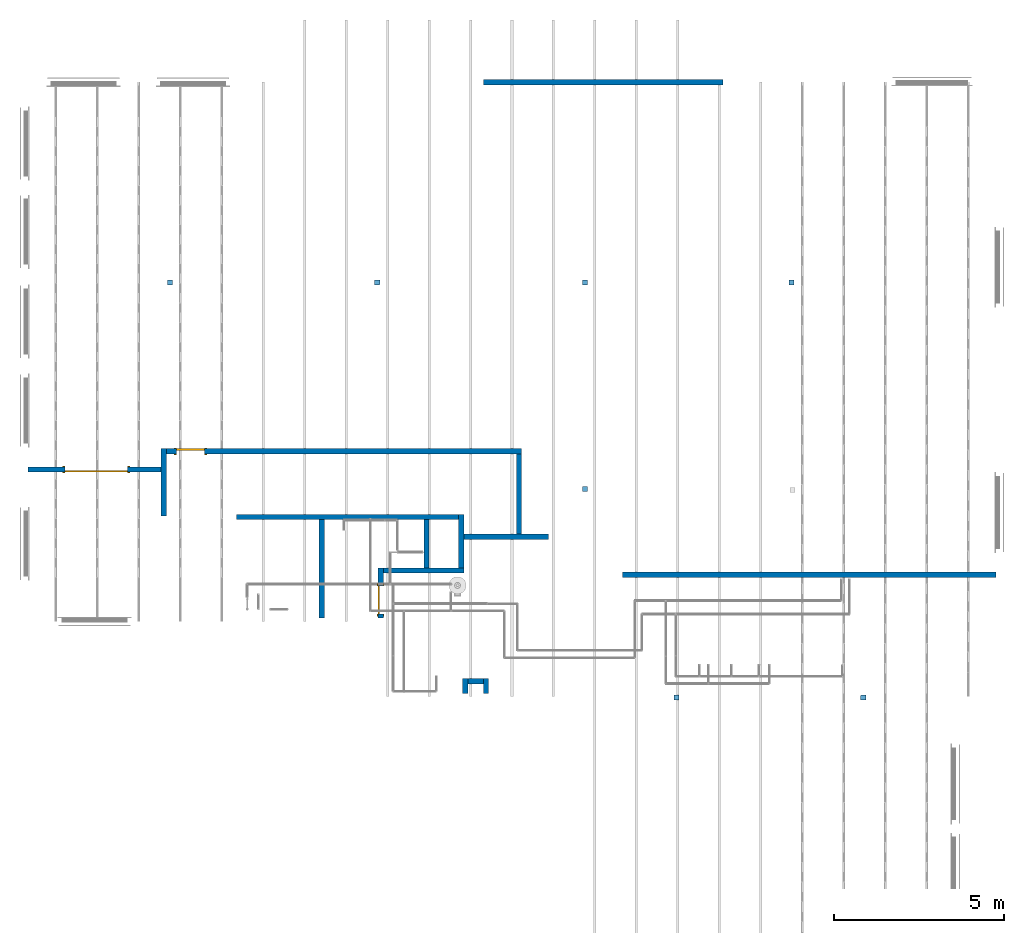
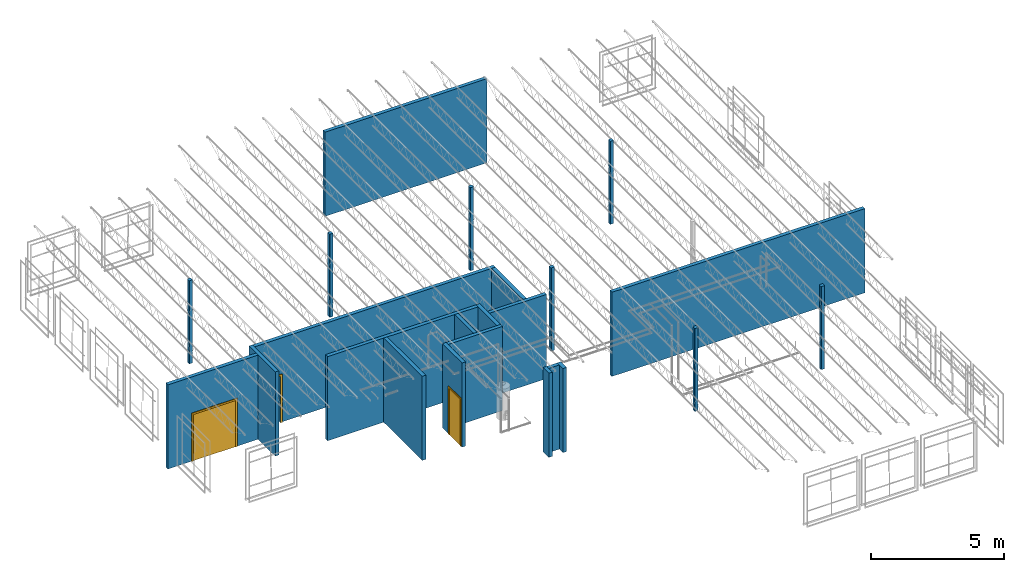
# One storey, part 1 of 31: 16 walls, 7 slabs, 3 doors, 3 openings.
"""IFC2X3 building model written with IfcOpenShell, lengths in feet."""

import ifcopenshell
import ifcopenshell.guid

model = None  # the IFC model being written
_history = None  # IfcOwnerHistory: only IFC2X3 demands one
_inside = {}  # id of a spatial element -> (the spatial element, [elements in it])
_under = {}  # id of a project, library or spatial element -> (it, [spatial elements below it])
_declared = {}  # id of a project -> (the project, [libraries it declares])
_typed = {}  # id of a type object -> (the type object, [elements of that type])
_made_of = {}  # id of a material, layer set ... -> (it, [elements and type objects made of it])


def new_model(schema):
    """Start an empty IFC model of exactly this schema.

    Asked for "IFC4X3", IfcOpenShell would pick the latest addendum, in which some entities
    have other attributes; the version numbers below select the first issue.
    IFC2X3 requires an IfcOwnerHistory on every rooted entity: one is made here for all.
    """
    global model, _history
    if schema == "IFC4X3":
        model = ifcopenshell.file(schema_version=(4, 3, 0, 0))
    else:
        model = ifcopenshell.file(schema=schema)
    _inside.clear()
    _under.clear()
    _declared.clear()
    _typed.clear()
    _made_of.clear()
    _history = None
    if model.schema == "IFC2X3":
        org = make("IfcOrganization", Name="unknown")
        user = make(
            "IfcPersonAndOrganization",
            ThePerson=make("IfcPerson", FamilyName="unknown"),
            TheOrganization=org,
        )
        app = make(
            "IfcApplication",
            ApplicationDeveloper=org,
            Version="unknown",
            ApplicationFullName="unknown",
            ApplicationIdentifier="unknown",
        )
        _history = make(
            "IfcOwnerHistory",
            OwningUser=user,
            OwningApplication=app,
            ChangeAction="ADDED",
            CreationDate=0,
        )
    return model


def make(cls, **values):
    """One entity of the class cls with the attributes given. An attribute that is None is left unset."""
    return model.create_entity(
        cls, **{name: value for name, value in values.items() if value is not None}
    )


def entity(cls, *values):
    """Any entity or typed value of the class cls, its attributes in the order of the schema. None: left unset."""
    e = model.create_entity(cls)
    for i, value in enumerate(values):
        if value is not None:
            e[i] = value
    return e


def rooted(cls, **values):
    """An entity with a GlobalId (a new one), such as an element, a storey or a relation."""
    return make(cls, GlobalId=ifcopenshell.guid.new(), OwnerHistory=_history, **values)


def si_unit(unit_type, name, prefix=None):
    """IfcSIUnit, for example si_unit("LENGTHUNIT", "METRE", prefix="MILLI")."""
    return make("IfcSIUnit", UnitType=unit_type, Prefix=prefix, Name=name)


def converted_unit(unit_type, name, factor, base, dimensions=None, offset=None):
    """IfcConversionBasedUnit, such as the inch: factor (a typed value) times the base unit."""
    return make(
        "IfcConversionBasedUnit"
        if offset is None
        else "IfcConversionBasedUnitWithOffset",
        ConversionOffset=offset,
        Dimensions=None
        if dimensions is None
        else entity("IfcDimensionalExponents", *dimensions),
        UnitType=unit_type,
        Name=name,
        ConversionFactor=make(
            "IfcMeasureWithUnit", ValueComponent=factor, UnitComponent=base
        ),
    )


def derived_unit(unit_type, elements):
    """IfcDerivedUnit: a product of units, each with its exponent."""
    return make(
        "IfcDerivedUnit",
        Elements=[
            make("IfcDerivedUnitElement", Unit=unit, Exponent=power)
            for unit, power in elements
        ],
        UnitType=unit_type,
    )


def assignment(units):
    """IfcUnitAssignment: the units of a project."""
    return None if units is None else make("IfcUnitAssignment", Units=units)


def point(xyz):
    """IfcCartesianPoint."""
    return None if xyz is None else make("IfcCartesianPoint", Coordinates=xyz)


def direction(xyz):
    """IfcDirection."""
    return None if xyz is None else make("IfcDirection", DirectionRatios=xyz)


def frame(location, z_axis=None, x_axis=None):
    """IfcAxis2Placement3D, a coordinate frame: its origin and axes. An axis left out is left unset."""
    return make(
        "IfcAxis2Placement3D",
        Location=point(location),
        Axis=direction(z_axis),
        RefDirection=direction(x_axis),
    )


def frame_2d(location, x_axis=None):
    """IfcAxis2Placement2D, a coordinate frame in the plane: its origin and x axis."""
    return make(
        "IfcAxis2Placement2D", Location=point(location), RefDirection=direction(x_axis)
    )


def origin():
    """The frame at (0, 0, 0) with its axes left unset."""
    return frame((0.0, 0.0, 0.0))


def origin_2d_with_axis():
    """The frame at (0, 0) in the plane with the x axis (1, 0) written out."""
    return frame_2d((0.0, 0.0), x_axis=(1.0, 0.0))


def place(relative_to, where):
    """IfcLocalPlacement: puts the frame where relative to a parent placement (None: the world)."""
    return make(
        "IfcLocalPlacement", PlacementRelTo=relative_to, RelativePlacement=where
    )


def context(
    kind, dimensions, precision=None, world=None, true_north=None, identifier=None
):
    """IfcGeometricRepresentationContext, for example the 3D "Model" context."""
    return make(
        "IfcGeometricRepresentationContext",
        ContextIdentifier=identifier,
        ContextType=kind,
        CoordinateSpaceDimension=dimensions,
        Precision=precision,
        WorldCoordinateSystem=world,
        TrueNorth=true_north,
    )


def subcontext(parent, identifier, kind, view, scale=None):
    """IfcGeometricRepresentationSubContext, for example "Body" below "Model"."""
    return make(
        "IfcGeometricRepresentationSubContext",
        ContextIdentifier=identifier,
        ContextType=kind,
        ParentContext=parent,
        TargetScale=scale,
        TargetView=view,
    )


def project(units=None, contexts=None):
    """IfcProject with its units and contexts."""
    return rooted(
        "IfcProject",
        Name="project",
        RepresentationContexts=contexts,
        UnitsInContext=assignment(units),
    )


def spatial(cls, under=None, at=None, **own):
    """A site, building, storey or space (cls), placed at a placement, below another one or the project."""
    s = rooted(cls, ObjectPlacement=at, **own)
    if under is not None:
        _under.setdefault(under.id(), (under, []))[1].append(s)
    return s


def polyline(points):
    """IfcPolyline through the points."""
    return make("IfcPolyline", Points=[point(p) for p in points])


def profile(cls, at=None, kind="AREA", **sizes):
    """A parametric profile (cls). Its sizes go by their IFC names, for example OverallWidth=200.0."""
    return make(cls, ProfileType=kind, Position=at, **sizes)


def rectangle(**sizes):
    """IfcRectangleProfileDef."""
    return profile("IfcRectangleProfileDef", **sizes)


def outline(outer, holes=None, kind="AREA"):
    """IfcArbitraryClosedProfileDef: a profile drawn as a closed curve; with holes, ...WithVoids."""
    if holes is None:
        return make("IfcArbitraryClosedProfileDef", ProfileType=kind, OuterCurve=outer)
    return make(
        "IfcArbitraryProfileDefWithVoids",
        ProfileType=kind,
        OuterCurve=outer,
        InnerCurves=holes,
    )


def extrude(swept, where, along, depth):
    """IfcExtrudedAreaSolid: the profile swept, set in the frame where, extruded along a direction by depth."""
    return make(
        "IfcExtrudedAreaSolid",
        SweptArea=swept,
        Position=where,
        ExtrudedDirection=direction(along),
        Depth=depth,
    )


def shape(context_of_items, identifier, shape_type, items):
    """IfcShapeRepresentation: the items that make up one representation, for example the "Body"."""
    return make(
        "IfcShapeRepresentation",
        ContextOfItems=context_of_items,
        RepresentationIdentifier=identifier,
        RepresentationType=shape_type,
        Items=items,
    )


def source(mapping_origin, context_of_items, identifier, shape_type, items):
    """IfcRepresentationMap: a shape defined once, which mapped items show again and again."""
    return make(
        "IfcRepresentationMap",
        MappingOrigin=mapping_origin,
        MappedRepresentation=shape(context_of_items, identifier, shape_type, items),
    )


def transform(
    local_origin,
    x_axis=None,
    y_axis=None,
    z_axis=None,
    scale=None,
    scale2=None,
    scale3=None,
    uniform=True,
):
    """IfcCartesianTransformationOperator3D, or its non-uniform kind. x_axis, y_axis, z_axis: its Axis1, 2, 3."""
    if uniform:
        return make(
            "IfcCartesianTransformationOperator3D",
            Axis1=direction(x_axis),
            Axis2=direction(y_axis),
            LocalOrigin=point(local_origin),
            Scale=scale,
            Axis3=direction(z_axis),
        )
    return make(
        "IfcCartesianTransformationOperator3DnonUniform",
        Axis1=direction(x_axis),
        Axis2=direction(y_axis),
        LocalOrigin=point(local_origin),
        Scale=scale,
        Axis3=direction(z_axis),
        Scale2=scale2,
        Scale3=scale3,
    )


def mapped(mapping_source, mapping_target):
    """IfcMappedItem: shows the shape of a source again, moved by a transform."""
    return make(
        "IfcMappedItem", MappingSource=mapping_source, MappingTarget=mapping_target
    )


def material(Name=None, Category=None):
    """IfcMaterial."""
    return make("IfcMaterial", Name=Name, Category=Category)


def material_list(materials):
    """IfcMaterialList."""
    return make("IfcMaterialList", Materials=materials)


def layer(
    of_material, thickness, ventilated=None, Name=None, Category=None, Priority=None
):
    """IfcMaterialLayer: one layer of a wall or slab, of a material (None: an air gap)."""
    return make(
        "IfcMaterialLayer",
        Material=of_material,
        LayerThickness=thickness,
        IsVentilated=ventilated,
        Name=Name,
        Category=Category,
        Priority=Priority,
    )


def layer_set(layers, Name=None):
    """IfcMaterialLayerSet."""
    return make("IfcMaterialLayerSet", MaterialLayers=layers, LayerSetName=Name)


def layer_usage(for_layer_set, set_direction, sense, offset, extent=None):
    """IfcMaterialLayerSetUsage: how a layer set lies in its element."""
    return make(
        "IfcMaterialLayerSetUsage",
        ForLayerSet=for_layer_set,
        LayerSetDirection=set_direction,
        DirectionSense=sense,
        OffsetFromReferenceLine=offset,
        ReferenceExtent=extent,
    )


def made_of(thing, what):
    """Note that an element or type object is made of a material, layer set ...; save() writes the relation."""
    if what is not None:
        _made_of.setdefault(what.id(), (what, []))[1].append(thing)
    return thing


def type_object(cls, material=None, **own):
    """A type object (cls), such as IfcWallType, which elements share."""
    return made_of(rooted(cls, **own), material)


def type_shapes(of_type, sources):
    """Give a type object the sources (RepresentationMaps) that its elements show as mapped items."""
    of_type.RepresentationMaps = sources


def element(
    cls,
    number,
    at=None,
    inside=None,
    cuts=None,
    type_object=None,
    material=None,
    context=None,
    identifier="Body",
    shape_type=None,
    held_by="IfcProductDefinitionShape",
    body=None,
    shapes=None,
    **own,
):
    """One element of the class cls, such as IfcWall. Its Tag is "e" and its number.

    at: its placement. inside: the storey or other place that contains it. cuts: it is an
    opening in that element (IfcRelVoidsElement). A single representation is given by context,
    identifier, shape_type and body (its items); several are given by shapes. held_by: the class
    of the entity that holds the representations. save() writes the other relations.
    """
    e = rooted(cls, Tag="e%d" % number, ObjectPlacement=at, **own)
    if body is not None:
        shapes = [shape(context, identifier, shape_type, body)]
    if shapes is not None:
        e.Representation = make(held_by, Representations=shapes)
    if inside is not None:
        _inside.setdefault(inside.id(), (inside, []))[1].append(e)
    if cuts is not None:
        rooted(
            "IfcRelVoidsElement", RelatingBuildingElement=cuts, RelatedOpeningElement=e
        )
    if type_object is not None:
        _typed.setdefault(type_object.id(), (type_object, []))[1].append(e)
    return made_of(e, material)


def fill(opening, filler):
    """IfcRelFillsElement: the door or window that sits in an opening."""
    return rooted(
        "IfcRelFillsElement",
        RelatingOpeningElement=opening,
        RelatedBuildingElement=filler,
    )


def aggregate(whole, parts):
    """IfcRelAggregates: a whole, such as a stair, and the parts it consists of."""
    return rooted("IfcRelAggregates", RelatingObject=whole, RelatedObjects=parts)


def save(model, path):
    """Write the relations noted so far, then the file.

    IfcRelAggregates (storeys below a building ...), IfcRelContainedInSpatialStructure (elements
    in a storey), IfcRelDefinesByType, IfcRelAssociatesMaterial and IfcRelDeclares: one each for
    every whole, place, type object, material and project.
    """
    for whole, parts in _under.values():
        aggregate(whole, parts)
    for where, things in _inside.values():
        rooted(
            "IfcRelContainedInSpatialStructure",
            RelatedElements=things,
            RelatingStructure=where,
        )
    for kind, things in _typed.values():
        rooted("IfcRelDefinesByType", RelatedObjects=things, RelatingType=kind)
    for what, things in _made_of.values():
        rooted("IfcRelAssociatesMaterial", RelatedObjects=things, RelatingMaterial=what)
    for by, libraries in _declared.values():
        rooted("IfcRelDeclares", RelatingContext=by, RelatedDefinitions=libraries)
    model.write(path)


model = new_model("IFC2X3")

# Units and contexts
model_context = context("Model", 3, precision=0.0001, world=origin(), true_north=direction((6.12303176911189e-17, 1.0)))
body_context = subcontext(model_context, "Body", "Model", "MODEL_VIEW")
ifc_project = project(units=[converted_unit("LENGTHUNIT", "FOOT", entity("IfcRatioMeasure", 0.3048), si_unit("LENGTHUNIT", "METRE"), dimensions=[1, 0, 0, 0, 0, 0, 0]), converted_unit("AREAUNIT", "SQUARE FOOT", entity("IfcRatioMeasure", 0.09290304), si_unit("AREAUNIT", "SQUARE_METRE"), dimensions=[2, 0, 0, 0, 0, 0, 0]), converted_unit("VOLUMEUNIT", "CUBIC FOOT", entity("IfcRatioMeasure", 0.028316846592), si_unit("VOLUMEUNIT", "CUBIC_METRE"), dimensions=[3, 0, 0, 0, 0, 0, 0]), converted_unit("PLANEANGLEUNIT", "DEGREE", entity("IfcRatioMeasure", 0.0174532925199433), si_unit("PLANEANGLEUNIT", "RADIAN"), dimensions=[0, 0, 0, 0, 0, 0, 0]), si_unit("MASSUNIT", "GRAM", prefix="KILO"), derived_unit("MASSDENSITYUNIT", [(si_unit("MASSUNIT", "GRAM", prefix="KILO"), 1), (si_unit("LENGTHUNIT", "METRE"), -3)]), si_unit("TIMEUNIT", "SECOND"), si_unit("FREQUENCYUNIT", "HERTZ"), si_unit("THERMODYNAMICTEMPERATUREUNIT", "DEGREE_CELSIUS"), derived_unit("THERMALTRANSMITTANCEUNIT", [(si_unit("MASSUNIT", "GRAM", prefix="KILO"), 1), (si_unit("THERMODYNAMICTEMPERATUREUNIT", "KELVIN"), -1), (si_unit("TIMEUNIT", "SECOND"), -3)]), derived_unit("VOLUMETRICFLOWRATEUNIT", [(si_unit("LENGTHUNIT", "METRE"), 3), (si_unit("TIMEUNIT", "SECOND"), -1)]), si_unit("ELECTRICCURRENTUNIT", "AMPERE"), si_unit("ELECTRICVOLTAGEUNIT", "VOLT"), si_unit("POWERUNIT", "WATT"), si_unit("FORCEUNIT", "NEWTON"), si_unit("ILLUMINANCEUNIT", "LUX"), si_unit("LUMINOUSFLUXUNIT", "LUMEN"), si_unit("LUMINOUSINTENSITYUNIT", "CANDELA"), derived_unit("USERDEFINED", [(si_unit("MASSUNIT", "GRAM", prefix="KILO"), -1), (si_unit("LENGTHUNIT", "METRE"), -2), (si_unit("TIMEUNIT", "SECOND"), 3), (si_unit("LUMINOUSFLUXUNIT", "LUMEN"), 1)]), derived_unit("LINEARVELOCITYUNIT", [(si_unit("LENGTHUNIT", "METRE"), 1), (si_unit("TIMEUNIT", "SECOND"), -1)]), si_unit("PRESSUREUNIT", "PASCAL"), derived_unit("USERDEFINED", [(si_unit("LENGTHUNIT", "METRE"), -2), (si_unit("MASSUNIT", "GRAM", prefix="KILO"), 1), (si_unit("TIMEUNIT", "SECOND"), -2)])], contexts=[model_context])

# Site, building, storey
site_placement = place(None, origin())
site = spatial("IfcSite", under=ifc_project, at=site_placement, CompositionType="ELEMENT")
building_placement = place(site_placement, origin())
building = spatial("IfcBuilding", under=site, at=building_placement, CompositionType="ELEMENT")
storey_placement = place(building_placement, frame((0.0, 0.0, 13.3333333333323)))
storey = spatial("IfcBuildingStorey", under=building, at=storey_placement, Name="Level 2", CompositionType="ELEMENT", Elevation=13.3333333333323)

# Slabs
slab_1_placement = place(building_placement, frame((0.0, 0.0, 13.3333333333323)))
element("IfcSlab", 1, at=slab_1_placement, inside=storey, ObjectType="BIMINONE_Square Pile:300x300:BIMINONE_Square Pile:300x300", PredefinedType="BASESLAB", context=body_context, shape_type="SweptSolid", body=[
    extrude(outline(polyline([(-0.217191601049862, -0.250000000000007), (0.217191601049862, -0.250000000000007), (0.25, -0.217191601049869), (0.25, 0.217191601049869), (0.217191601049862, 0.250000000000007), (-0.217191601049876, 0.250000000000007), (-0.25, 0.217191601049883), (-0.25, -0.217191601049869), (-0.217191601049862, -0.250000000000007)])), frame((34.6619876003292, 34.7012074729218, 0.164041994752646)), (0.0, 0.0, 1.0), 12.502624671916),
])
slab_2_placement = place(building_placement, frame((0.0, 0.0, 13.3333333333323)))
element("IfcSlab", 2, at=slab_2_placement, inside=storey, ObjectType="BIMINONE_Square Pile:300x300:BIMINONE_Square Pile:300x300", PredefinedType="BASESLAB", context=body_context, shape_type="SweptSolid", body=[
    extrude(outline(polyline([(-0.217191601049869, -0.250000000000007), (0.217191601049867, -0.250000000000007), (0.25, -0.217191601049876), (0.25, 0.217191601049869), (0.217191601049871, 0.25), (-0.217191601049871, 0.25), (-0.250000000000002, 0.217191601049869), (-0.250000000000002, -0.217191601049876), (-0.217191601049869, -0.250000000000007)])), frame((14.7453209336625, 34.7012074729217, 0.164041994752646)), (0.0, 0.0, 1.0), 12.502624671916),
])
slab_3_placement = place(building_placement, frame((0.0, 0.0, 13.3333333333323)))
element("IfcSlab", 3, at=slab_3_placement, inside=storey, ObjectType="BIMINONE_Square Pile:300x300:BIMINONE_Square Pile:300x300", PredefinedType="BASESLAB", context=body_context, shape_type="SweptSolid", body=[
    extrude(outline(polyline([(-0.217191601049868, -0.25), (0.217191601049869, -0.25), (0.249999999999998, -0.217191601049869), (0.249999999999998, 0.217191601049876), (0.217191601049874, 0.250000000000007), (-0.217191601049867, 0.250000000000007), (-0.249999999999999, 0.217191601049876), (-0.249999999999999, -0.217191601049869), (-0.217191601049868, -0.25)])), frame((-5.28600073082738, 34.7012074729218, 0.164041994752646)), (0.0, 0.0, 1.0), 12.502624671916),
])
slab_4_placement = place(building_placement, frame((0.0, 0.0, 13.3333333333323)))
element("IfcSlab", 4, at=slab_4_placement, inside=storey, ObjectType="BIMINONE_Square Pile:300x300:BIMINONE_Square Pile:300x300", PredefinedType="BASESLAB", context=body_context, shape_type="SweptSolid", body=[
    extrude(outline(polyline([(-0.217191601049862, -0.249999999999993), (0.21719160104988, -0.249999999999993), (0.250000000000021, -0.217191601049848), (0.250000000000021, 0.217191601049819), (0.217191601049848, 0.249999999999993), (-0.217191601049876, 0.249999999999993), (-0.25, 0.217191601049869), (-0.25, -0.217191601049855), (-0.217191601049862, -0.249999999999993)])), frame((-25.267589670528, 34.7012074729218, 0.164041994752646)), (0.0, 0.0, 1.0), 12.502624671916),
])
slab_5_placement = place(building_placement, frame((0.0, 0.0, 13.3333333333323)))
element("IfcSlab", 5, at=slab_5_placement, inside=storey, ObjectType="BIMINONE_Square Pile:300x300:BIMINONE_Square Pile:300x300", PredefinedType="BASESLAB", context=body_context, shape_type="SweptSolid", body=[
    extrude(outline(polyline([(-0.217191601049866, -0.250000000000005), (0.217191601049867, -0.250000000000005), (0.250000000000004, -0.217191601049871), (0.250000000000004, 0.217191601049869), (0.217191601049871, 0.250000000000002), (-0.217191601049873, 0.250000000000002), (-0.250000000000002, 0.217191601049871), (-0.250000000000002, -0.217191601049869), (-0.217191601049866, -0.250000000000005)])), frame((14.7453209336625, 14.784540806255, 0.164041994752646)), (0.0, 0.0, 1.0), 12.502624671916),
])
slab_6_placement = place(building_placement, frame((0.0, 0.0, 13.3333333333323)))
element("IfcSlab", 6, at=slab_6_placement, inside=storey, ObjectType="BIMINONE_Square Pile:300x300:BIMINONE_Square Pile:300x300", PredefinedType="BASESLAB", context=body_context, shape_type="SweptSolid", body=[
    extrude(outline(polyline([(-0.217191601049866, -0.250000000000002), (0.217191601049869, -0.250000000000002), (0.250000000000004, -0.217191601049867), (0.250000000000004, 0.217191601049869), (0.217191601049873, 0.249999999999999), (-0.217191601049869, 0.249999999999999), (-0.249999999999993, 0.217191601049876), (-0.249999999999993, -0.217191601049874), (-0.217191601049866, -0.250000000000002)])), frame((23.5821254511809, -5.33561336783727, 0.164041994752646)), (0.0, 0.0, 1.0), 12.502624671916),
])
slab_7_placement = place(building_placement, frame((0.0, 0.0, 13.3333333333323)))
element("IfcSlab", 7, at=slab_7_placement, inside=storey, ObjectType="BIMINONE_Square Pile:300x300:BIMINONE_Square Pile:300x300", PredefinedType="BASESLAB", context=body_context, shape_type="SweptSolid", body=[
    extrude(outline(polyline([(-0.217191601049862, -0.250000000000005), (0.217191601049869, -0.250000000000005), (0.250000000000014, -0.217191601049864), (0.250000000000014, 0.217191601049858), (0.217191601049869, 0.250000000000004), (-0.217191601049869, 0.250000000000004), (-0.25, 0.217191601049874), (-0.25, -0.217191601049867), (-0.217191601049862, -0.250000000000005)])), frame((41.5821254511809, -5.33561336783727, 0.164041994752646)), (0.0, 0.0, 1.0), 12.502624671916),
])

# Wall, opening, door
ifc_material_1 = material(Name="Gypsum Wall Board")
ifc_layer_1 = layer(ifc_material_1, 0.0520833333333333)
ifc_layer_2 = layer(ifc_material_1, 0.0520833333333333)
ifc_material_2 = material(Name="Metal Stud Layer")
ifc_layer_3 = layer(ifc_material_2, 0.302083333333333)
ifc_layer_4 = layer(ifc_material_1, 0.0520833333333333)
ifc_layer_5 = layer(ifc_material_1, 0.0520833333333333)
ifc_layer_set = layer_set([ifc_layer_1, ifc_layer_2, ifc_layer_3, ifc_layer_4, ifc_layer_5])
ifc_layer_usage_1 = layer_usage(ifc_layer_set, "AXIS2", "NEGATIVE", 0.255208333333333)
wall_type = type_object("IfcWallType", PredefinedType="STANDARD", material=ifc_layer_set)
wall_1_placement = place(building_placement, frame((-38.9526673974941, 16.6588982913686, 13.3333333333323)))
wall_1 = element("IfcWallStandardCase", 8, at=wall_1_placement, inside=storey, type_object=wall_type, material=ifc_layer_usage_1, context=body_context, shape_type="SweptSolid", body=[
    extrude(rectangle(XDim=12.828125, YDim=0.510416666666664, at=frame_2d((6.41406250000001, 0.0), x_axis=(-1.0, 0.0))), origin(), (0.0, 0.0, 1.0), 12.6666666666667),
])
opening_1_placement = place(wall_1_placement, frame((38.9526673974941, -16.6588982913686, 0.0)))
opening_1 = element("IfcOpeningElement", 9, at=opening_1_placement, cuts=wall_1, ObjectType="Opening", context=body_context, shape_type="SweptSolid", body=[
    extrude(rectangle(XDim=7.0, YDim=6.0, at=frame_2d((-1.77635683940025e-15, 0.0), x_axis=(1.0, 0.0))), frame((-32.3693340641607, 16.3985857913686, 3.49999999999999), z_axis=(0.0, 1.0, 0.0), x_axis=(0.0, 0.0, -1.0)), (0.0, 0.0, 1.0), 0.520625000000003),
])
ifc_material_3 = material(Name="Wood - Birch - Solid Stained Light Low Gloss")
ifc_material_4 = material(Name="Paint - Sienna")
ifc_material_list_1 = material_list([ifc_material_3, ifc_material_4])
ifc_material_list_2 = material_list([ifc_material_3, ifc_material_4])
door_style_1 = type_object("IfcDoorStyle", ConstructionType="NOTDEFINED", OperationType="NOTDEFINED", ParameterTakesPrecedence=False, Sizeable=False, material=ifc_material_list_2)
shared_shape_1 = source(origin(), body_context, "Body", "SweptSolid", [
    extrude(rectangle(XDim=2.99999999999999, YDim=0.166666666666667, at=origin_2d_with_axis()), frame((1.50000000000001, 0.432187500000011, 0.0)), (0.0, 0.0, 1.0), 7.0),
    extrude(rectangle(XDim=3.0, YDim=0.16666666666665, at=origin_2d_with_axis()), frame((4.50000000000001, 0.432187499999998, 0.0)), (0.0, 0.0, 1.0), 7.0),
    extrude(outline(polyline([(3.0, -3.5625), (3.25, -3.5625), (3.25, 3.6875), (-3.25, 3.6875), (-3.25, -3.5625), (-3.0, -3.5625), (-3.0, 3.4375), (3.0, 3.4375), (3.0, -3.5625)])), frame((3.0, 0.515520833333339, 3.5625), z_axis=(0.0, 1.0, 0.0), x_axis=(-1.0, 0.0, 0.0)), (0.0, 0.0, 1.0), 0.0833333333333333),
    extrude(outline(polyline([(3.0, -3.5625), (3.25, -3.5625), (3.25, 3.6875), (-3.25, 3.6875), (-3.25, -3.5625), (-3.0, -3.5625), (-3.0, 3.4375), (3.0, 3.4375), (3.0, -3.5625)])), frame((3.0, -0.0782291666666604, 3.5625), z_axis=(0.0, 1.0, 0.0), x_axis=(-1.0, 0.0, 0.0)), (0.0, 0.0, 1.0), 0.0833333333333333),
])
type_shapes(door_style_1, [shared_shape_1])
door_1_placement = place(opening_1_placement, frame((-29.3693340641607, 16.9192107913686, 0.0), z_axis=(0.0, 0.0, 1.0), x_axis=(-1.0, 0.0, 0.0)))
door_1 = element("IfcDoor", 10, at=door_1_placement, inside=storey, type_object=door_style_1, material=ifc_material_list_1, OverallHeight=6.0, OverallWidth=7.0, context=body_context, shape_type="MappedRepresentation", body=[
    mapped(shared_shape_1, transform((0.0, 0.0, 0.0), scale=1.0)),
])
fill(opening_1, door_1)

# Wall
ifc_layer_usage_2 = layer_usage(ifc_layer_set, "AXIS2", "NEGATIVE", 0.255208333333333)
wall_2_placement = place(building_placement, frame((-25.8693340641607, 18.6641066247019, 13.3333333333323), z_axis=(0.0, 0.0, 1.0), x_axis=(0.0, -1.0, 0.0)))
element("IfcWallStandardCase", 11, at=wall_2_placement, inside=storey, type_object=wall_type, material=ifc_layer_usage_2, context=body_context, shape_type="SweptSolid", body=[
    extrude(rectangle(XDim=6.4861062777813, YDim=0.510416666666664, at=frame_2d((3.24305313889065, 0.0), x_axis=(-1.0, 0.0))), origin(), (0.0, 0.0, 1.0), 12.6666666666667),
])

# Wall, opening, door
ifc_layer_usage_3 = layer_usage(ifc_layer_set, "AXIS2", "NEGATIVE", 0.255208333333333)
wall_3_placement = place(building_placement, frame((-25.6141257308274, 18.4088982913686, 13.3333333333323)))
wall_3 = element("IfcWallStandardCase", 12, at=wall_3_placement, inside=storey, type_object=wall_type, material=ifc_layer_usage_3, context=body_context, shape_type="SweptSolid", body=[
    extrude(rectangle(XDim=34.25, YDim=0.510416666666664, at=frame_2d((17.125, 0.0), x_axis=(-1.0, 0.0))), origin(), (0.0, 0.0, 1.0), 12.6666666666667),
])
opening_2_placement = place(wall_3_placement, frame((25.6141257308274, -18.4088982913686, 0.0)))
opening_2 = element("IfcOpeningElement", 13, at=opening_2_placement, cuts=wall_3, ObjectType="Opening", context=body_context, shape_type="SweptSolid", body=[
    extrude(rectangle(XDim=7.0, YDim=2.66666666666666, at=frame_2d((-8.88178419700125e-16, 0.0), x_axis=(1.0, 0.0))), frame((-23.2860007308274, 18.1485857913686, 3.49999999999999), z_axis=(0.0, 1.0, 0.0), x_axis=(0.0, 0.0, -1.0)), (0.0, 0.0, 1.0), 0.520625000000003),
])
ifc_material_5 = material(Name="Door - Panel")
ifc_material_6 = material(Name="Door - Frame")
ifc_material_list_3 = material_list([ifc_material_5, ifc_material_6])
ifc_material_list_4 = material_list([ifc_material_5, ifc_material_6])
door_style_2 = type_object("IfcDoorStyle", ConstructionType="NOTDEFINED", OperationType="NOTDEFINED", ParameterTakesPrecedence=False, Sizeable=False, material=ifc_material_list_4)
shared_shape_2 = source(origin(), body_context, "Body", "SweptSolid", [
    extrude(rectangle(XDim=2.66666666666667, YDim=0.166666666666667, at=origin_2d_with_axis()), frame((1.33333333333333, -0.0884374999999989, 0.0), z_axis=(0.0, 0.0, 1.0), x_axis=(-1.0, 0.0, 0.0)), (0.0, 0.0, 1.0), 7.0),
    extrude(outline(polyline([(-1.58333333333332, -3.5625), (-1.33333333333336, -3.5625), (-1.33333333333336, 3.4375), (1.33333333333334, 3.4375), (1.33333333333334, -3.5625), (1.58333333333334, -3.5625), (1.58333333333334, 3.6875), (-1.58333333333332, 3.6875), (-1.58333333333332, -3.5625)])), frame((1.33333333333334, -0.598854166666666, 3.5625), z_axis=(0.0, 1.0, 0.0), x_axis=(-1.0, 0.0, 0.0)), (0.0, 0.0, 1.0), 0.0833333333333333),
    extrude(outline(polyline([(-3.6875, -1.58333333333333), (3.5625, -1.58333333333333), (3.5625, -1.33333333333333), (-3.43750000000001, -1.33333333333333), (-3.43750000000001, 1.33333333333333), (3.5625, 1.33333333333333), (3.5625, 1.58333333333333), (-3.6875, 1.58333333333333), (-3.6875, -1.58333333333333)])), frame((1.33333333333333, -0.00510416666666563, 3.5625), z_axis=(0.0, 1.0, 0.0), x_axis=(0.0, 0.0, -1.0)), (0.0, 0.0, 1.0), 0.0833333333333333),
])
type_shapes(door_style_2, [shared_shape_2])
door_2_placement = place(opening_2_placement, frame((-24.6193340641607, 18.6692107913686, 0.0)))
door_2 = element("IfcDoor", 14, at=door_2_placement, inside=storey, type_object=door_style_2, material=ifc_material_list_3, OverallHeight=2.66666666666666, OverallWidth=7.0, context=body_context, shape_type="MappedRepresentation", body=[
    mapped(shared_shape_2, transform((0.0, 0.0, 0.0), scale=1.0)),
])
fill(opening_2, door_2)

# Walls
ifc_layer_usage_4 = layer_usage(ifc_layer_set, "AXIS2", "NEGATIVE", 0.255208333333333)
wall_4_placement = place(building_placement, frame((8.38066593583926, 18.1536899580352, 13.3333333333323), z_axis=(0.0, 0.0, 1.0), x_axis=(0.0, -1.0, 0.0)))
element("IfcWallStandardCase", 15, at=wall_4_placement, inside=storey, type_object=wall_type, material=ifc_layer_usage_4, context=body_context, shape_type="SweptSolid", body=[
    extrude(rectangle(XDim=7.72548151592431, YDim=0.510416666666668, at=frame_2d((3.86274075796216, 0.0), x_axis=(-1.0, 0.0))), origin(), (0.0, 0.0, 1.0), 12.6666666666667),
])
ifc_layer_usage_5 = layer_usage(ifc_layer_set, "AXIS2", "NEGATIVE", 0.255208333333333)
wall_5_placement = place(building_placement, frame((11.2175995719933, 10.1730001087776, 13.3333333333323), z_axis=(0.0, 0.0, 1.0), x_axis=(-1.0, 0.0, 0.0)))
element("IfcWallStandardCase", 16, at=wall_5_placement, inside=storey, type_object=wall_type, material=ifc_layer_usage_5, context=body_context, shape_type="SweptSolid", body=[
    extrude(rectangle(XDim=8.15464196948734, YDim=0.510416666666668, at=frame_2d((4.07732098474367, 0.0), x_axis=(-1.0, 0.0))), origin(), (0.0, 0.0, 1.0), 12.6666666666667),
])
ifc_layer_usage_6 = layer_usage(ifc_layer_set, "AXIS2", "NEGATIVE", 0.255208333333333)
wall_6_placement = place(building_placement, frame((2.80774926917259, 7.16931495803515, 13.3333333333323), z_axis=(0.0, 0.0, 1.0), x_axis=(0.0, 1.0, 0.0)))
element("IfcWallStandardCase", 17, at=wall_6_placement, inside=storey, type_object=wall_type, material=ifc_layer_usage_6, context=body_context, shape_type="SweptSolid", body=[
    extrude(rectangle(XDim=5.16145833333333, YDim=0.510416666666666, at=frame_2d((2.58072916666667, 0.0), x_axis=(-1.0, 0.0))), origin(), (0.0, 0.0, 1.0), 12.6666666666667),
])
ifc_layer_usage_7 = layer_usage(ifc_layer_set, "AXIS2", "NEGATIVE", 0.255208333333333)
wall_7_placement = place(building_placement, frame((2.55254093583925, 12.0755649580352, 13.3333333333323), z_axis=(0.0, 0.0, 1.0), x_axis=(-1.0, 0.0, 0.0)))
element("IfcWallStandardCase", 18, at=wall_7_placement, inside=storey, type_object=wall_type, material=ifc_layer_usage_7, context=body_context, shape_type="SweptSolid", body=[
    extrude(rectangle(XDim=21.4203725495413, YDim=0.510416666666668, at=frame_2d((10.7101862747706, 0.0), x_axis=(-1.0, 0.0))), origin(), (0.0, 0.0, 1.0), 12.6666666666667),
])
ifc_layer_usage_8 = layer_usage(ifc_layer_set, "AXIS2", "NEGATIVE", 0.255208333333333)
wall_8_placement = place(building_placement, frame((-10.6349590641607, 11.8203566247018, 13.3333333333323), z_axis=(0.0, 0.0, 1.0), x_axis=(0.0, -1.0, 0.0)))
element("IfcWallStandardCase", 19, at=wall_8_placement, inside=storey, type_object=wall_type, material=ifc_layer_usage_8, context=body_context, shape_type="SweptSolid", body=[
    extrude(rectangle(XDim=9.48958333333333, YDim=0.510416666666668, at=frame_2d((4.74479166666667, 0.0), x_axis=(-1.0, 0.0))), origin(), (0.0, 0.0, 1.0), 12.6666666666667),
])

# Wall, opening, door
ifc_layer_usage_9 = layer_usage(ifc_layer_set, "AXIS2", "NEGATIVE", 0.255208333333333)
wall_9_placement = place(building_placement, frame((-4.95266739749409, 2.33077329136849, 13.3333333333323), z_axis=(0.0, 0.0, 1.0), x_axis=(0.0, 1.0, 0.0)))
wall_9 = element("IfcWallStandardCase", 20, at=wall_9_placement, inside=storey, type_object=wall_type, material=ifc_layer_usage_9, context=body_context, shape_type="SweptSolid", body=[
    extrude(rectangle(XDim=4.83854166666667, YDim=0.510416666666666, at=frame_2d((2.41927083333333, 0.0), x_axis=(-1.0, 0.0))), origin(), (0.0, 0.0, 1.0), 12.6666666666667),
])
opening_3_placement = place(wall_9_placement, frame((-2.33077329136849, -4.95266739749409, 0.0), z_axis=(0.0, 0.0, 1.0), x_axis=(0.0, -1.0, 0.0)))
opening_3 = element("IfcOpeningElement", 21, at=opening_3_placement, cuts=wall_9, ObjectType="Opening", context=body_context, shape_type="SweptSolid", body=[
    extrude(rectangle(XDim=7.0, YDim=2.66666666666667, at=frame_2d((1.77635683940025e-15, 0.0), x_axis=(1.0, 0.0))), frame((-4.69235489749409, 4.08077329136849, 3.49999999999999), z_axis=(-1.0, 0.0, 0.0), x_axis=(0.0, 0.0, 1.0)), (0.0, 0.0, 1.0), 0.520625),
])
ifc_material_list_5 = material_list([ifc_material_5, ifc_material_6])
ifc_material_list_6 = material_list([ifc_material_5, ifc_material_6])
door_style_3 = type_object("IfcDoorStyle", ConstructionType="NOTDEFINED", OperationType="NOTDEFINED", ParameterTakesPrecedence=False, Sizeable=False, material=ifc_material_list_6)
shared_shape_3 = source(origin(), body_context, "Body", "SweptSolid", [
    extrude(rectangle(XDim=0.166666666666667, YDim=2.66666666666667, at=origin_2d_with_axis()), frame((1.33333333333333, -0.0884375000000195, 0.0), z_axis=(0.0, 0.0, 1.0), x_axis=(0.0, 1.0, 0.0)), (0.0, 0.0, 1.0), 7.0),
    extrude(outline(polyline([(-3.5625, -1.58333333333333), (3.6875, -1.58333333333333), (3.6875, 1.58333333333333), (-3.5625, 1.58333333333333), (-3.5625, 1.33333333333333), (3.4375, 1.33333333333333), (3.4375, -1.33333333333333), (-3.5625, -1.33333333333333), (-3.5625, -1.58333333333333)])), frame((1.33333333333333, -0.598854166666666, 3.5625), z_axis=(0.0, 1.0, 0.0), x_axis=(0.0, 0.0, 1.0)), (0.0, 0.0, 1.0), 0.0833333333333333),
    extrude(outline(polyline([(-1.58333333333333, -3.6875), (1.58333333333333, -3.6875), (1.58333333333333, 3.5625), (1.33333333333333, 3.5625), (1.33333333333333, -3.43750000000001), (-1.33333333333333, -3.43750000000001), (-1.33333333333333, 3.5625), (-1.58333333333333, 3.5625), (-1.58333333333333, -3.6875)])), frame((1.33333333333333, -0.00510416666668623, 3.5625), z_axis=(0.0, 1.0, 0.0), x_axis=(1.0, 0.0, 0.0)), (0.0, 0.0, 1.0), 0.0833333333333333),
])
type_shapes(door_style_3, [shared_shape_3])
door_3_placement = place(opening_3_placement, frame((-5.21297989749409, 2.74743995803515, 0.0), z_axis=(0.0, 0.0, 1.0), x_axis=(0.0, 1.0, 0.0)))
door_3 = element("IfcDoor", 22, at=door_3_placement, inside=storey, type_object=door_style_3, material=ifc_material_list_5, OverallHeight=2.66666666666667, OverallWidth=7.0, context=body_context, shape_type="MappedRepresentation", body=[
    mapped(shared_shape_3, transform((0.0, 0.0, 0.0), scale=1.0)),
])
fill(opening_3, door_3)

# Walls
ifc_layer_usage_10 = layer_usage(ifc_layer_set, "AXIS2", "NEGATIVE", 0.255208333333333)
wall_10_placement = place(building_placement, frame((-4.69745906416076, 6.91410662470182, 13.3333333333323)))
element("IfcWallStandardCase", 23, at=wall_10_placement, inside=storey, type_object=wall_type, material=ifc_layer_usage_10, context=body_context, shape_type="SweptSolid", body=[
    extrude(rectangle(XDim=7.76041666666668, YDim=0.510416666666666, at=frame_2d((3.88020833333334, 0.0), x_axis=(-1.0, 0.0))), origin(), (0.0, 0.0, 1.0), 12.6666666666667),
])
ifc_layer_usage_11 = layer_usage(ifc_layer_set, "AXIS2", "NEGATIVE", 0.255208333333333)
wall_11_placement = place(building_placement, frame((-0.53600073082742, 7.16931495803515, 13.3333333333323), z_axis=(0.0, 0.0, 1.0), x_axis=(0.0, 1.0, 0.0)))
element("IfcWallStandardCase", 24, at=wall_11_placement, inside=storey, type_object=wall_type, material=ifc_layer_usage_11, context=body_context, shape_type="SweptSolid", body=[
    extrude(rectangle(XDim=4.65104166666667, YDim=0.510416666666667, at=frame_2d((2.32552083333333, 0.0), x_axis=(-1.0, 0.0))), origin(), (0.0, 0.0, 1.0), 12.6666666666667),
])
ifc_layer_usage_12 = layer_usage(ifc_layer_set, "AXIS2", "NEGATIVE", 0.255208333333333)
wall_12_placement = place(building_placement, frame((18.3842662386599, 6.52088272376916, 13.3333333333323)))
element("IfcWallStandardCase", 25, at=wall_12_placement, inside=storey, type_object=wall_type, material=ifc_layer_usage_12, context=body_context, shape_type="SweptSolid", body=[
    extrude(rectangle(XDim=35.9963996971794, YDim=0.510416666666666, at=frame_2d((17.9981998485897, 0.0), x_axis=(-1.0, 0.0))), origin(), (0.0, 0.0, 1.0), 12.6666666666667),
])
ifc_layer_usage_13 = layer_usage(ifc_layer_set, "AXIS2", "NEGATIVE", 0.255208333333333)
wall_13_placement = place(building_placement, frame((4.95879093583932, 53.9974399580351, 13.3333333333323)))
element("IfcWallStandardCase", 26, at=wall_13_placement, inside=storey, type_object=wall_type, material=ifc_layer_usage_13, context=body_context, shape_type="SweptSolid", body=[
    extrude(rectangle(XDim=23.0833333333333, YDim=0.510416666666671, at=frame_2d((11.5416666666667, 0.0), x_axis=(-1.0, 0.0))), origin(), (0.0, 0.0, 1.0), 12.6666666666667),
])
ifc_layer_usage_14 = layer_usage(ifc_layer_set, "AXIS2", "NEGATIVE", 0.255208333333333)
wall_14_placement = place(building_placement, frame((3.21399926917257, -4.91922670863151, 13.3333333333323), z_axis=(0.0, 0.0, 1.0), x_axis=(0.0, 1.0, 0.0)))
element("IfcWallStandardCase", 27, at=wall_14_placement, inside=storey, type_object=wall_type, material=ifc_layer_usage_14, context=body_context, shape_type="SweptSolid", body=[
    extrude(rectangle(XDim=1.421875, YDim=0.510416666666667, at=frame_2d((0.7109375, 0.0), x_axis=(-1.0, 0.0))), origin(), (0.0, 0.0, 1.0), 12.6666666666667),
])
ifc_layer_usage_15 = layer_usage(ifc_layer_set, "AXIS2", "NEGATIVE", 0.255208333333333)
wall_15_placement = place(building_placement, frame((3.4692076025059, -3.75256004196485, 13.3333333333323)))
element("IfcWallStandardCase", 28, at=wall_15_placement, inside=storey, type_object=wall_type, material=ifc_layer_usage_15, context=body_context, shape_type="SweptSolid", body=[
    extrude(rectangle(XDim=1.48958333333333, YDim=0.510416666666667, at=frame_2d((0.744791666666667, 0.0), x_axis=(-1.0, 0.0))), origin(), (0.0, 0.0, 1.0), 12.6666666666667),
])
ifc_layer_usage_16 = layer_usage(ifc_layer_set, "AXIS2", "NEGATIVE", 0.255208333333333)
wall_16_placement = place(building_placement, frame((5.21399926917257, -3.49735170863151, 13.3333333333323), z_axis=(0.0, 0.0, 1.0), x_axis=(0.0, -1.0, 0.0)))
element("IfcWallStandardCase", 29, at=wall_16_placement, inside=storey, type_object=wall_type, material=ifc_layer_usage_16, context=body_context, shape_type="SweptSolid", body=[
    extrude(rectangle(XDim=1.421875, YDim=0.510416666666666, at=frame_2d((0.7109375, 0.0), x_axis=(-1.0, 0.0))), origin(), (0.0, 0.0, 1.0), 12.6666666666667),
])

save(model, "model.ifc")
